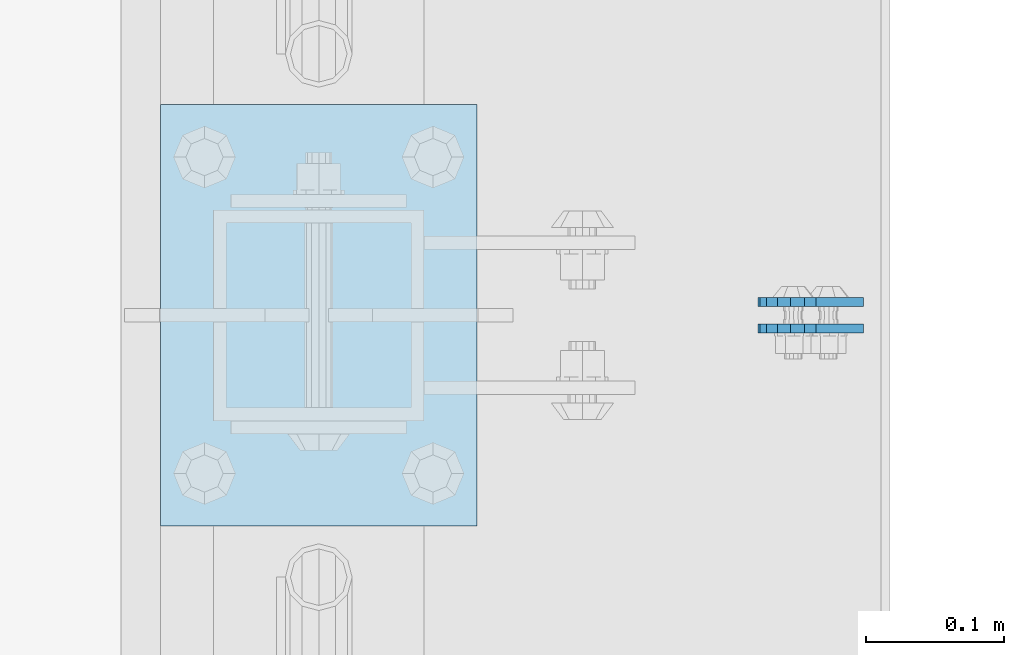
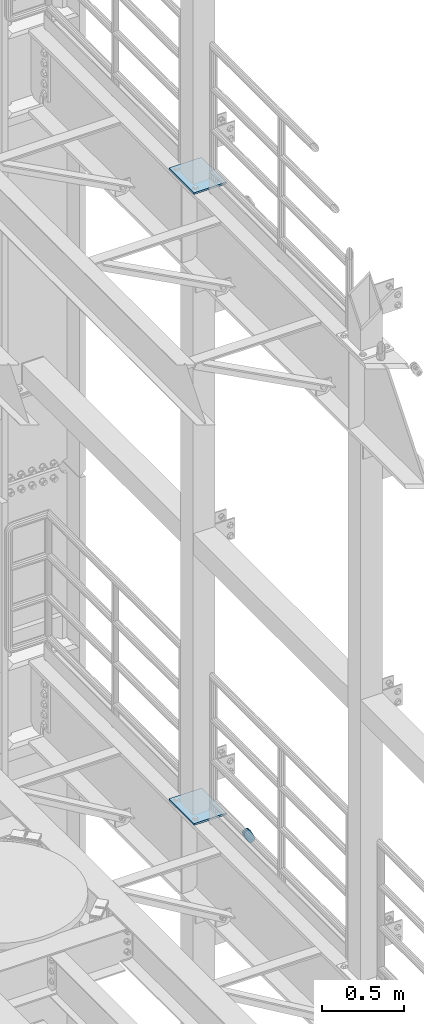
# One storey, part 1821 of 1876: 4 plates, 4 elements without a shape of their own.
"""IFC2X3 building model written with IfcOpenShell, lengths in millimetres."""

import ifcopenshell
import ifcopenshell.guid

model = None  # the IFC model being written
_history = None  # IfcOwnerHistory: only IFC2X3 demands one
_inside = {}  # id of a spatial element -> (the spatial element, [elements in it])
_under = {}  # id of a project, library or spatial element -> (it, [spatial elements below it])
_declared = {}  # id of a project -> (the project, [libraries it declares])
_typed = {}  # id of a type object -> (the type object, [elements of that type])
_made_of = {}  # id of a material, layer set ... -> (it, [elements and type objects made of it])


def new_model(schema):
    """Start an empty IFC model of exactly this schema.

    Asked for "IFC4X3", IfcOpenShell would pick the latest addendum, in which some entities
    have other attributes; the version numbers below select the first issue.
    IFC2X3 requires an IfcOwnerHistory on every rooted entity: one is made here for all.
    """
    global model, _history
    if schema == "IFC4X3":
        model = ifcopenshell.file(schema_version=(4, 3, 0, 0))
    else:
        model = ifcopenshell.file(schema=schema)
    _inside.clear()
    _under.clear()
    _declared.clear()
    _typed.clear()
    _made_of.clear()
    _history = None
    if model.schema == "IFC2X3":
        org = make("IfcOrganization", Name="unknown")
        user = make(
            "IfcPersonAndOrganization",
            ThePerson=make("IfcPerson", FamilyName="unknown"),
            TheOrganization=org,
        )
        app = make(
            "IfcApplication",
            ApplicationDeveloper=org,
            Version="unknown",
            ApplicationFullName="unknown",
            ApplicationIdentifier="unknown",
        )
        _history = make(
            "IfcOwnerHistory",
            OwningUser=user,
            OwningApplication=app,
            ChangeAction="ADDED",
            CreationDate=0,
        )
    return model


def make(cls, **values):
    """One entity of the class cls with the attributes given. An attribute that is None is left unset."""
    return model.create_entity(
        cls, **{name: value for name, value in values.items() if value is not None}
    )


def rooted(cls, **values):
    """An entity with a GlobalId (a new one), such as an element, a storey or a relation."""
    return make(cls, GlobalId=ifcopenshell.guid.new(), OwnerHistory=_history, **values)


def si_unit(unit_type, name, prefix=None):
    """IfcSIUnit, for example si_unit("LENGTHUNIT", "METRE", prefix="MILLI")."""
    return make("IfcSIUnit", UnitType=unit_type, Prefix=prefix, Name=name)


def assignment(units):
    """IfcUnitAssignment: the units of a project."""
    return None if units is None else make("IfcUnitAssignment", Units=units)


def point(xyz):
    """IfcCartesianPoint."""
    return None if xyz is None else make("IfcCartesianPoint", Coordinates=xyz)


def direction(xyz):
    """IfcDirection."""
    return None if xyz is None else make("IfcDirection", DirectionRatios=xyz)


def frame(location, z_axis=None, x_axis=None):
    """IfcAxis2Placement3D, a coordinate frame: its origin and axes. An axis left out is left unset."""
    return make(
        "IfcAxis2Placement3D",
        Location=point(location),
        Axis=direction(z_axis),
        RefDirection=direction(x_axis),
    )


def origin_with_axes():
    """The frame at (0, 0, 0) with the z axis (0, 0, 1) and the x axis (1, 0, 0) written out."""
    return frame((0.0, 0.0, 0.0), z_axis=(0.0, 0.0, 1.0), x_axis=(1.0, 0.0, 0.0))


def place(relative_to, where):
    """IfcLocalPlacement: puts the frame where relative to a parent placement (None: the world)."""
    return make(
        "IfcLocalPlacement", PlacementRelTo=relative_to, RelativePlacement=where
    )


def context(
    kind, dimensions, precision=None, world=None, true_north=None, identifier=None
):
    """IfcGeometricRepresentationContext, for example the 3D "Model" context."""
    return make(
        "IfcGeometricRepresentationContext",
        ContextIdentifier=identifier,
        ContextType=kind,
        CoordinateSpaceDimension=dimensions,
        Precision=precision,
        WorldCoordinateSystem=world,
        TrueNorth=true_north,
    )


def subcontext(parent, identifier, kind, view, scale=None):
    """IfcGeometricRepresentationSubContext, for example "Body" below "Model"."""
    return make(
        "IfcGeometricRepresentationSubContext",
        ContextIdentifier=identifier,
        ContextType=kind,
        ParentContext=parent,
        TargetScale=scale,
        TargetView=view,
    )


def project(units=None, contexts=None):
    """IfcProject with its units and contexts."""
    return rooted(
        "IfcProject",
        Name="project",
        RepresentationContexts=contexts,
        UnitsInContext=assignment(units),
    )


def spatial(cls, under=None, at=None, **own):
    """A site, building, storey or space (cls), placed at a placement, below another one or the project."""
    s = rooted(cls, ObjectPlacement=at, **own)
    if under is not None:
        _under.setdefault(under.id(), (under, []))[1].append(s)
    return s


def faces_of(points, faces, orient=None, outer=None):
    """IfcFace entities. A face is a list of loops; a loop is a list of indices into points, from 0.

    orient and outer hold one flag for each loop. By default every Orientation is true, the
    first loop of a face is its IfcFaceOuterBound and the others are IfcFaceBound.
    """
    made = []
    for i, loops in enumerate(faces):
        bounds = []
        for j, loop in enumerate(loops):
            is_outer = j == 0 if outer is None else outer[i][j]
            bounds.append(
                make(
                    "IfcFaceOuterBound" if is_outer else "IfcFaceBound",
                    Bound=make("IfcPolyLoop", Polygon=[points[k] for k in loop]),
                    Orientation=True if orient is None else orient[i][j],
                )
            )
        made.append(make("IfcFace", Bounds=bounds))
    return made


def faceted_brep(points, faces, orient=None, outer=None, voids=None):
    """IfcFacetedBrep: a solid bounded by flat faces; with voids (closed shells), ...WithVoids."""
    shared = [point(p) for p in points]
    hull = make("IfcClosedShell", CfsFaces=faces_of(shared, faces, orient, outer))
    if voids is None:
        return make("IfcFacetedBrep", Outer=hull)
    return make(
        "IfcFacetedBrepWithVoids",
        Outer=hull,
        Voids=[
            make(cls, CfsFaces=faces_of(shared, fs, o, b)) for cls, fs, o, b in voids
        ],
    )


def shape(context_of_items, identifier, shape_type, items):
    """IfcShapeRepresentation: the items that make up one representation, for example the "Body"."""
    return make(
        "IfcShapeRepresentation",
        ContextOfItems=context_of_items,
        RepresentationIdentifier=identifier,
        RepresentationType=shape_type,
        Items=items,
    )


def material(Name=None, Category=None):
    """IfcMaterial."""
    return make("IfcMaterial", Name=Name, Category=Category)


def made_of(thing, what):
    """Note that an element or type object is made of a material, layer set ...; save() writes the relation."""
    if what is not None:
        _made_of.setdefault(what.id(), (what, []))[1].append(thing)
    return thing


def type_object(cls, material=None, **own):
    """A type object (cls), such as IfcWallType, which elements share."""
    return made_of(rooted(cls, **own), material)


def element(
    cls,
    number,
    at=None,
    inside=None,
    cuts=None,
    type_object=None,
    material=None,
    context=None,
    identifier="Body",
    shape_type=None,
    held_by="IfcProductDefinitionShape",
    body=None,
    shapes=None,
    **own,
):
    """One element of the class cls, such as IfcWall. Its Tag is "e" and its number.

    at: its placement. inside: the storey or other place that contains it. cuts: it is an
    opening in that element (IfcRelVoidsElement). A single representation is given by context,
    identifier, shape_type and body (its items); several are given by shapes. held_by: the class
    of the entity that holds the representations. save() writes the other relations.
    """
    e = rooted(cls, Tag="e%d" % number, ObjectPlacement=at, **own)
    if body is not None:
        shapes = [shape(context, identifier, shape_type, body)]
    if shapes is not None:
        e.Representation = make(held_by, Representations=shapes)
    if inside is not None:
        _inside.setdefault(inside.id(), (inside, []))[1].append(e)
    if cuts is not None:
        rooted(
            "IfcRelVoidsElement", RelatingBuildingElement=cuts, RelatedOpeningElement=e
        )
    if type_object is not None:
        _typed.setdefault(type_object.id(), (type_object, []))[1].append(e)
    return made_of(e, material)


def aggregate(whole, parts):
    """IfcRelAggregates: a whole, such as a stair, and the parts it consists of."""
    return rooted("IfcRelAggregates", RelatingObject=whole, RelatedObjects=parts)


def save(model, path):
    """Write the relations noted so far, then the file.

    IfcRelAggregates (storeys below a building ...), IfcRelContainedInSpatialStructure (elements
    in a storey), IfcRelDefinesByType, IfcRelAssociatesMaterial and IfcRelDeclares: one each for
    every whole, place, type object, material and project.
    """
    for whole, parts in _under.values():
        aggregate(whole, parts)
    for where, things in _inside.values():
        rooted(
            "IfcRelContainedInSpatialStructure",
            RelatedElements=things,
            RelatingStructure=where,
        )
    for kind, things in _typed.values():
        rooted("IfcRelDefinesByType", RelatedObjects=things, RelatingType=kind)
    for what, things in _made_of.values():
        rooted("IfcRelAssociatesMaterial", RelatedObjects=things, RelatingMaterial=what)
    for by, libraries in _declared.values():
        rooted("IfcRelDeclares", RelatingContext=by, RelatedDefinitions=libraries)
    model.write(path)


model = new_model("IFC2X3")

# Units and contexts
model_context = context("Model", 3, precision=1e-05, world=origin_with_axes())
body_context = subcontext(model_context, "Body", "Model", "MODEL_VIEW")
ifc_project = project(units=[si_unit("LENGTHUNIT", "METRE", prefix="MILLI"), si_unit("AREAUNIT", "SQUARE_METRE"), si_unit("VOLUMEUNIT", "CUBIC_METRE"), si_unit("MASSUNIT", "GRAM", prefix="KILO"), si_unit("TIMEUNIT", "SECOND"), si_unit("PLANEANGLEUNIT", "RADIAN"), si_unit("SOLIDANGLEUNIT", "STERADIAN"), si_unit("THERMODYNAMICTEMPERATUREUNIT", "DEGREE_CELSIUS"), si_unit("LUMINOUSINTENSITYUNIT", "LUMEN")], contexts=[model_context])

# Site, building, storey
site_placement = place(None, origin_with_axes())
site = spatial("IfcSite", under=ifc_project, at=site_placement, CompositionType="ELEMENT")
building_placement = place(site_placement, origin_with_axes())
building = spatial("IfcBuilding", under=site, at=building_placement, Name="Undefined", CompositionType="ELEMENT")
storey_placement = place(building_placement, origin_with_axes())
storey = spatial("IfcBuildingStorey", under=building, at=storey_placement, Name="Undefined", CompositionType="ELEMENT", Elevation=0.0)

# Assembly, plate
assembly_1_placement = place(storey_placement, origin_with_axes())
assembly_1 = element("IfcElementAssembly", 1, at=assembly_1_placement, inside=storey, Name="PLATE", AssemblyPlace="NOTDEFINED", PredefinedType="RIGID_FRAME")
ifc_material = material(Name="STEEL/A36")
plate_type_1 = type_object("IfcPlateType", PredefinedType="NOTDEFINED")
plate_1_placement = place(assembly_1_placement, frame((7974.16265107819, 11674.4750023123, 13038.8776774809), z_axis=(-0.894427191199917, 1.49999996210681e-08, -0.447213595099955), x_axis=(0.447213595099955, -6.99999707257281e-09, -0.894427191199917)))
plate_1 = element("IfcPlate", 2, at=plate_1_placement, type_object=plate_type_1, material=ifc_material, Name="PLATE", context=body_context, shape_type="Brep", body=[
    faceted_brep([(-8.59611645864788e-07, -3.17499999999654, 25.3999987589127), (1.93345873884391, -3.17499999999382, 35.1201580589886), (1.93345873884391, 3.17500000000564, 35.1201580589886), (-8.59611645864788e-07, 3.17500000000382, 25.3999987589132), (7.43948648259902, -3.17499999999109, 43.3605112870105), (7.43948648259902, 3.17500000000928, 43.3605112870105), (15.6798395242777, -3.17499999998654, 48.8665393096448), (15.6798395242777, 3.17500000001382, 48.8665393096448), (25.3999987589095, -3.17499999998199, 50.7999992370592), (25.3999987589095, 3.17500000001837, 50.7999992370592), (82.196130752618, -3.17499999998381, 50.7999992370605), (82.196130752618, 3.17500000001655, 50.7999992370642), (91.9162897887145, -3.17499999997926, 48.8665393918873), (91.9162897887145, 3.1750000000211, 48.8665393918909), (100.156642725027, -3.17499999997472, 43.3605115909359), (100.156642725027, 3.17500000002565, 43.3605115909395), (105.662670525982, -3.17499999997108, 35.1201586546285), (105.662670525986, 3.17500000002929, 35.1201586546358), (107.596130371159, -3.17499999996744, 25.3999996185757), (107.596130371159, 3.17500000003292, 25.3999996185794), (105.662670525981, -3.17499999996471, 15.6798405824902), (105.662670525981, 3.17500000003565, 15.6798405824939), (100.156642725024, -3.17499999996471, 7.43948764618654), (100.156642725025, 3.17500000003565, 7.43948764619017), (91.9162897887127, -3.17499999996562, 1.93345984522784), (91.9162897887127, 3.17500000003474, 1.93345984523148), (82.196130752618, -3.17499999996835, 4.54747350886464e-11), (82.196130752618, 3.1750000000311, 4.91127138957381e-11), (25.399998758905, -3.17499999999018, -8.64019966684282e-12), (25.399998758905, 3.17500000001019, -8.64019966684282e-12), (15.679839921364, -3.17499999999382, 1.9334597629304), (15.679839921364, 3.17500000000655, 1.9334597629304), (7.43948709043525, -3.17499999999654, 7.43948734220839), (7.43948709043525, 3.17500000000382, 7.43948734220885), (1.93345923228208, -3.17499999999654, 15.6798399868012), (1.93345923228208, 3.17500000000291, 15.6798399868012)], [[[0, 1, 2, 3]], [[1, 4, 5, 2]], [[4, 6, 7, 5]], [[6, 8, 9, 7]], [[8, 10, 11, 9]], [[10, 12, 13, 11]], [[12, 14, 15, 13]], [[14, 16, 17, 15]], [[16, 18, 19, 17]], [[18, 20, 21, 19]], [[20, 22, 23, 21]], [[22, 24, 25, 23]], [[24, 26, 27, 25]], [[26, 28, 29, 27]], [[28, 30, 31, 29]], [[30, 32, 33, 31]], [[32, 34, 35, 33]], [[34, 0, 3, 35]], [[5, 7, 9, 11, 13, 15, 17, 19, 21, 23, 25, 27, 29, 31, 33, 35, 3, 2]], [[34, 32, 30, 28, 26, 24, 22, 20, 18, 16, 14, 12, 10, 8, 6, 4, 1, 0]]]),
])
aggregate(assembly_1, [plate_1])

assembly_2_placement = place(storey_placement, origin_with_axes())
assembly_2 = element("IfcElementAssembly", 3, at=assembly_2_placement, inside=storey, Name="PLATE", AssemblyPlace="NOTDEFINED", PredefinedType="RIGID_FRAME")
plate_2_placement = place(assembly_2_placement, frame((7974.16265167476, 11693.536198617, 13038.8776774809), z_axis=(-0.894427191199917, 1.49999996210681e-08, -0.447213595099955), x_axis=(0.447213595099955, -6.99999707257281e-09, -0.894427191199917)))
plate_2 = element("IfcPlate", 4, at=plate_2_placement, type_object=plate_type_1, material=ifc_material, Name="PLATE", context=body_context, shape_type="Brep", body=[
    faceted_brep([(-8.59611645864788e-07, -3.17499999999654, 25.3999987589127), (1.93345873884391, -3.17499999999382, 35.1201580589886), (1.93345873884391, 3.17500000000564, 35.1201580589886), (-8.59611645864788e-07, 3.17500000000382, 25.3999987589132), (7.43948648259902, -3.17499999999109, 43.3605112870105), (7.43948648259902, 3.17500000000928, 43.3605112870105), (15.6798395242777, -3.17499999998654, 48.8665393096448), (15.6798395242777, 3.17500000001382, 48.8665393096448), (25.3999987589095, -3.17499999998199, 50.7999992370592), (25.3999987589095, 3.17500000001837, 50.7999992370592), (82.196130752618, -3.17499999998381, 50.7999992370605), (82.196130752618, 3.17500000001655, 50.7999992370642), (91.9162897887145, -3.17499999997926, 48.8665393918873), (91.9162897887145, 3.1750000000211, 48.8665393918909), (100.156642725027, -3.17499999997472, 43.3605115909359), (100.156642725027, 3.17500000002565, 43.3605115909395), (105.662670525982, -3.17499999997108, 35.1201586546285), (105.662670525986, 3.17500000002929, 35.1201586546358), (107.596130371159, -3.17499999996744, 25.3999996185757), (107.596130371159, 3.17500000003292, 25.3999996185794), (105.662670525981, -3.17499999996471, 15.6798405824902), (105.662670525981, 3.17500000003565, 15.6798405824939), (100.156642725024, -3.17499999996471, 7.43948764618654), (100.156642725025, 3.17500000003565, 7.43948764619017), (91.9162897887127, -3.17499999996562, 1.93345984522784), (91.9162897887127, 3.17500000003474, 1.93345984523148), (82.196130752618, -3.17499999996835, 4.54747350886464e-11), (82.196130752618, 3.1750000000311, 4.91127138957381e-11), (25.399998758905, -3.17499999999018, -8.64019966684282e-12), (25.399998758905, 3.17500000001019, -8.64019966684282e-12), (15.679839921364, -3.17499999999382, 1.9334597629304), (15.679839921364, 3.17500000000655, 1.9334597629304), (7.43948709043525, -3.17499999999654, 7.43948734220839), (7.43948709043525, 3.17500000000382, 7.43948734220885), (1.93345923228208, -3.17499999999654, 15.6798399868012), (1.93345923228208, 3.17500000000291, 15.6798399868012)], [[[0, 1, 2, 3]], [[1, 4, 5, 2]], [[4, 6, 7, 5]], [[6, 8, 9, 7]], [[8, 10, 11, 9]], [[10, 12, 13, 11]], [[12, 14, 15, 13]], [[14, 16, 17, 15]], [[16, 18, 19, 17]], [[18, 20, 21, 19]], [[20, 22, 23, 21]], [[22, 24, 25, 23]], [[24, 26, 27, 25]], [[26, 28, 29, 27]], [[28, 30, 31, 29]], [[30, 32, 33, 31]], [[32, 34, 35, 33]], [[34, 0, 3, 35]], [[5, 7, 9, 11, 13, 15, 17, 19, 21, 23, 25, 27, 29, 31, 33, 35, 3, 2]], [[34, 32, 30, 28, 26, 24, 22, 20, 18, 16, 14, 12, 10, 8, 6, 4, 1, 0]]]),
])
aggregate(assembly_2, [plate_2])

assembly_3_placement = place(storey_placement, origin_with_axes())
assembly_3 = element("IfcElementAssembly", 5, at=assembly_3_placement, inside=storey, Name="BEAM", AssemblyPlace="NOTDEFINED", PredefinedType="RIGID_FRAME")
plate_type_2 = type_object("IfcPlateType", PredefinedType="NOTDEFINED")
plate_3_placement = place(assembly_3_placement, frame((7505.7, 11531.6, 17989.55), z_axis=(0.0, 1.0, 0.0), x_axis=(1.0, 0.0, 0.0)))
plate_3 = element("IfcPlate", 6, at=plate_3_placement, type_object=plate_type_2, material=ifc_material, Name="PLATE", context=body_context, shape_type="Brep", body=[
    faceted_brep([(0.0, -6.35000000000036, 0.0), (0.0, -6.35000000000036, 304.799987792969), (0.0, 6.35000000000036, 304.799987792969), (0.0, 6.35000000000036, 0.0), (228.600006103516, -6.34999999999854, 304.799987792969), (228.600006103516, 6.34999999999854, 304.799987792969), (228.600006103516, -6.34999999999854, 0.0), (228.600006103516, 6.34999999999854, 0.0)], [[[0, 1, 2, 3]], [[1, 4, 5, 2]], [[4, 6, 7, 5]], [[6, 0, 3, 7]], [[5, 7, 3, 2]], [[6, 4, 1, 0]]]),
])
aggregate(assembly_3, [plate_3])

assembly_4_placement = place(storey_placement, origin_with_axes())
assembly_4 = element("IfcElementAssembly", 7, at=assembly_4_placement, inside=storey, Name="BEAM", AssemblyPlace="NOTDEFINED", PredefinedType="RIGID_FRAME")
plate_4_placement = place(assembly_4_placement, frame((7505.7, 11531.6, 13315.95), z_axis=(0.0, 1.0, 0.0), x_axis=(1.0, 0.0, 0.0)))
plate_4 = element("IfcPlate", 8, at=plate_4_placement, type_object=plate_type_2, material=ifc_material, Name="PLATE", context=body_context, shape_type="Brep", body=[
    faceted_brep([(0.0, -6.35000000000036, 0.0), (0.0, -6.35000000000036, 304.799987792969), (0.0, 6.35000000000036, 304.799987792969), (0.0, 6.35000000000036, 0.0), (228.600006103516, -6.34999999999854, 304.799987792969), (228.600006103516, 6.34999999999854, 304.799987792969), (228.600006103516, -6.34999999999854, 0.0), (228.600006103516, 6.34999999999854, 0.0)], [[[0, 1, 2, 3]], [[1, 4, 5, 2]], [[4, 6, 7, 5]], [[6, 0, 3, 7]], [[5, 7, 3, 2]], [[6, 4, 1, 0]]]),
])
aggregate(assembly_4, [plate_4])

save(model, "model.ifc")
